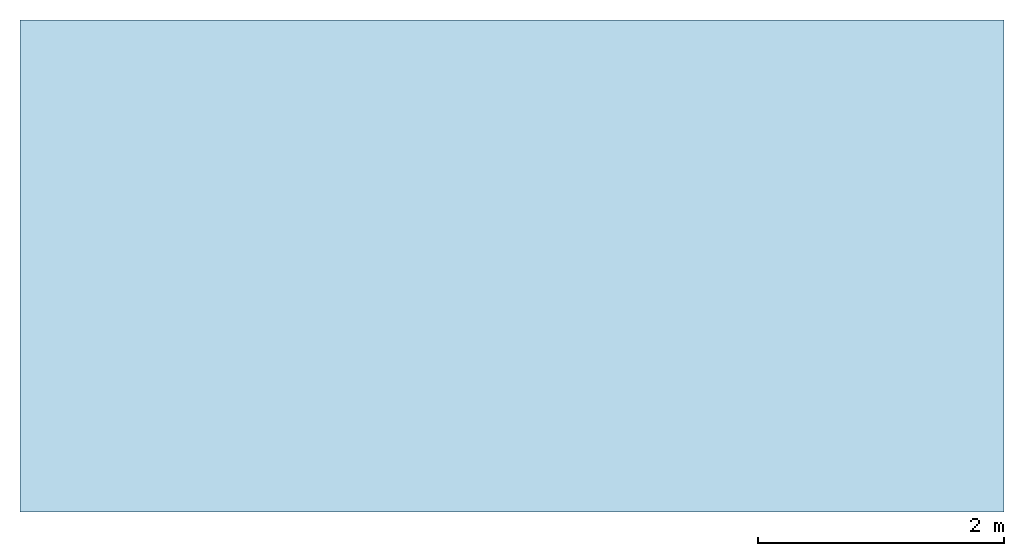
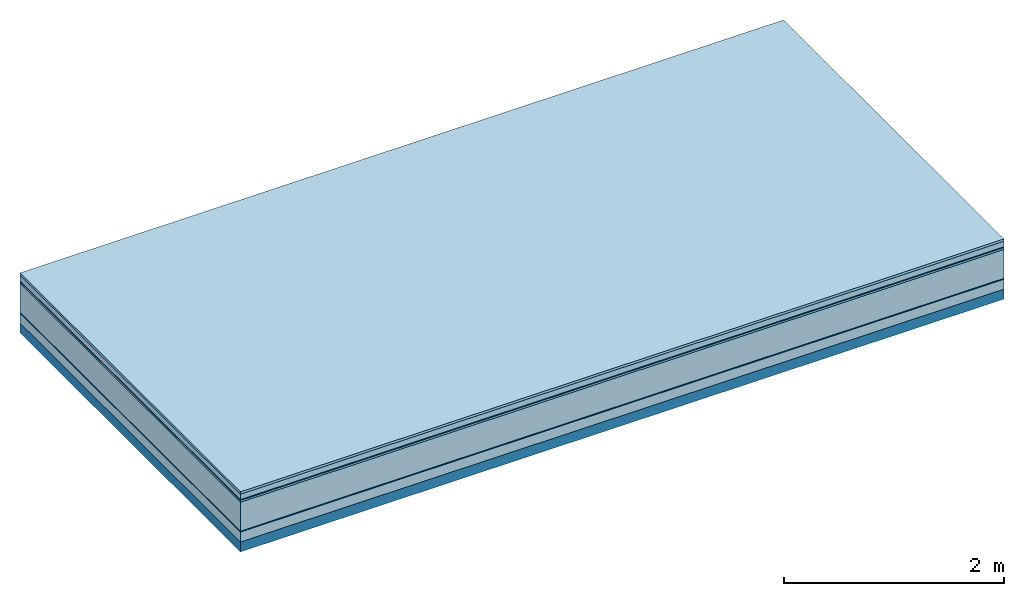
# One storey: 7 plates, 1 member, 1 element without a shape of its own.
"""IFC4 building model written with IfcOpenShell, lengths in metres."""

from ifc_helpers import new_model, si_unit, derived_unit, direction, frame, frame_2d, origin, origin_with_axes, place, context, project, spatial, rectangle, extrude, material, layer, layer_set, type_object, element, aggregate, save


model = new_model("IFC4")

# Units and contexts
plan_context = context("Plan", 3, precision=1e-05, world=origin(), true_north=direction((0.0, 1.0)))
model_context = context("Model", 3, precision=1e-05, world=origin(), true_north=direction((0.0, 1.0)))
ifc_project = project(units=[si_unit("LENGTHUNIT", "METRE"), derived_unit("SOUNDPRESSUREUNIT", [(si_unit("PRESSUREUNIT", "PASCAL", prefix="MICRO"), 0)]), si_unit("ENERGYUNIT", "JOULE", prefix="MEGA"), si_unit("MASSUNIT", "GRAM", prefix="KILO"), derived_unit("THERMALTRANSMITTANCEUNIT", [(si_unit("POWERUNIT", "WATT"), 1), (si_unit("AREAUNIT", "SQUARE_METRE"), -1), (si_unit("THERMODYNAMICTEMPERATUREUNIT", "KELVIN"), -1)]), derived_unit("AREADENSITYUNIT", [(si_unit("MASSUNIT", "GRAM", prefix="KILO"), 1), (si_unit("AREAUNIT", "SQUARE_METRE"), -1)]), derived_unit("USERDEFINED", [(si_unit("ENERGYUNIT", "JOULE", prefix="MEGA"), 1), (si_unit("AREAUNIT", "SQUARE_METRE"), -1)])], contexts=[plan_context, model_context])

# Site, building, storey
site = spatial("IfcSite", under=ifc_project)
building_placement = place(None, origin())
building = spatial("IfcBuilding", under=site, at=building_placement)
storey_placement = place(building_placement, origin())
storey = spatial("IfcBuildingStorey", under=building, at=storey_placement)

# Slab, member, plates
ifc_material_1 = material(Category="07.009")
ifc_layer_1 = layer(ifc_material_1, 0.026, Name="Use and protection layer 3")
ifc_material_2 = material(Category="07.011")
ifc_layer_2 = layer(ifc_material_2, 0.06, Name="Use and protection layer 2")
ifc_material_3 = material(Name="Protective layer + Fire protection cover RF1", Category="09.007")
ifc_layer_3 = layer(ifc_material_3, 0.01, Name="Use and protection layer 1")
ifc_material_4 = material(Name="Bituminous", Category="09.003")
ifc_layer_4 = layer(ifc_material_4, 0.02, Name="Seal")
ifc_material_5 = material(Name="Mineral wool", Category="10.008")
ifc_layer_5 = layer(ifc_material_5, 0.32, Name="Exterior insulation layer 1")
ifc_material_6 = material(Name="Vapor-permeable barrier", Category="09.006")
ifc_layer_6 = layer(ifc_material_6, 0.01, Name="layer / temporary roof")
ifc_material_7 = material(Category="01.002")
ifc_layer_7 = layer(ifc_material_7, 0.11, Name="above 1st layer")
ifc_material_8 = material(Name="Rigid, of the art")
ifc_layer_8 = layer(ifc_material_8, 0.0, Name="Bond")
ifc_layer_9 = layer(None, 0.11, Name="Support")
ifc_layer_set = layer_set([ifc_layer_1, ifc_layer_2, ifc_layer_3, ifc_layer_4, ifc_layer_5, ifc_layer_6, ifc_layer_7, ifc_layer_8, ifc_layer_9])
slab_type = type_object("IfcSlabType", Name="F0081", PredefinedType="NOTDEFINED", material=ifc_layer_set)
slab_placement = place(None, frame((0.0, 0.0, 0.0), z_axis=(0.0, 0.0, -1.0), x_axis=(1.0, 0.0, 0.0)))
slab = element("IfcSlab", 1, at=slab_placement, inside=storey, type_object=slab_type, material=ifc_layer_set, Name="Slab #1")
ifc_material_9 = material(Name="Solid timber panel")
member_placement = place(slab_placement, origin())
member = element("IfcMember", 2, at=member_placement, material=ifc_material_9, Name="Support", context=plan_context, shape_type="SweptSolid", body=[
    extrude(rectangle(XDim=1.0, YDim=0.11, at=frame_2d((0.5, 0.055), x_axis=(1.0, 0.0))), frame((0.0, 4.0, 0.556), z_axis=(0.0, -1.0, 0.0), x_axis=(1.0, 0.0, 0.0)), (0.0, 0.0, 1.0), 4.0),
    extrude(rectangle(XDim=1.0, YDim=0.11, at=frame_2d((0.5, 0.055), x_axis=(1.0, 0.0))), frame((1.0, 4.0, 0.556), z_axis=(0.0, -1.0, 0.0), x_axis=(1.0, 0.0, 0.0)), (0.0, 0.0, 1.0), 4.0),
    extrude(rectangle(XDim=1.0, YDim=0.11, at=frame_2d((0.5, 0.055), x_axis=(1.0, 0.0))), frame((2.0, 4.0, 0.556), z_axis=(0.0, -1.0, 0.0), x_axis=(1.0, 0.0, 0.0)), (0.0, 0.0, 1.0), 4.0),
    extrude(rectangle(XDim=1.0, YDim=0.11, at=frame_2d((0.5, 0.055), x_axis=(1.0, 0.0))), frame((3.0, 4.0, 0.556), z_axis=(0.0, -1.0, 0.0), x_axis=(1.0, 0.0, 0.0)), (0.0, 0.0, 1.0), 4.0),
    extrude(rectangle(XDim=1.0, YDim=0.11, at=frame_2d((0.5, 0.055), x_axis=(1.0, 0.0))), frame((4.0, 4.0, 0.556), z_axis=(0.0, -1.0, 0.0), x_axis=(1.0, 0.0, 0.0)), (0.0, 0.0, 1.0), 4.0),
    extrude(rectangle(XDim=1.0, YDim=0.11, at=frame_2d((0.5, 0.055), x_axis=(1.0, 0.0))), frame((5.0, 4.0, 0.556), z_axis=(0.0, -1.0, 0.0), x_axis=(1.0, 0.0, 0.0)), (0.0, 0.0, 1.0), 4.0),
    extrude(rectangle(XDim=1.0, YDim=0.11, at=frame_2d((0.5, 0.055), x_axis=(1.0, 0.0))), frame((6.0, 4.0, 0.556), z_axis=(0.0, -1.0, 0.0), x_axis=(1.0, 0.0, 0.0)), (0.0, 0.0, 1.0), 4.0),
    extrude(rectangle(XDim=1.0, YDim=0.11, at=frame_2d((0.5, 0.055), x_axis=(1.0, 0.0))), frame((7.0, 4.0, 0.556), z_axis=(0.0, -1.0, 0.0), x_axis=(1.0, 0.0, 0.0)), (0.0, 0.0, 1.0), 4.0),
])
plate_1_placement = place(slab_placement, origin())
plate_1 = element("IfcPlate", 3, at=plate_1_placement, material=ifc_material_1, Name="Use and protection layer 3", context=plan_context, shape_type="SweptSolid", body=[
    extrude(rectangle(XDim=8.0, YDim=4.0, at=frame_2d((4.0, 2.0), x_axis=(1.0, 0.0))), origin_with_axes(), (0.0, 0.0, 1.0), 0.026),
])
plate_2_placement = place(slab_placement, origin())
plate_2 = element("IfcPlate", 4, at=plate_2_placement, material=ifc_material_2, Name="Use and protection layer 2", context=plan_context, shape_type="SweptSolid", body=[
    extrude(rectangle(XDim=8.0, YDim=4.0, at=frame_2d((4.0, 2.0), x_axis=(1.0, 0.0))), frame((0.0, 0.0, 0.026), z_axis=(0.0, 0.0, 1.0), x_axis=(1.0, 0.0, 0.0)), (0.0, 0.0, 1.0), 0.06),
])
plate_3_placement = place(slab_placement, origin())
plate_3 = element("IfcPlate", 5, at=plate_3_placement, material=ifc_material_3, Name="Use and protection layer 1", context=plan_context, shape_type="SweptSolid", body=[
    extrude(rectangle(XDim=8.0, YDim=4.0, at=frame_2d((4.0, 2.0), x_axis=(1.0, 0.0))), frame((0.0, 0.0, 0.086), z_axis=(0.0, 0.0, 1.0), x_axis=(1.0, 0.0, 0.0)), (0.0, 0.0, 1.0), 0.01),
])
plate_4_placement = place(slab_placement, origin())
plate_4 = element("IfcPlate", 6, at=plate_4_placement, material=ifc_material_4, Name="Seal", context=plan_context, shape_type="SweptSolid", body=[
    extrude(rectangle(XDim=8.0, YDim=4.0, at=frame_2d((4.0, 2.0), x_axis=(1.0, 0.0))), frame((0.0, 0.0, 0.096), z_axis=(0.0, 0.0, 1.0), x_axis=(1.0, 0.0, 0.0)), (0.0, 0.0, 1.0), 0.02),
])
plate_5_placement = place(slab_placement, origin())
plate_5 = element("IfcPlate", 7, at=plate_5_placement, material=ifc_material_5, Name="Exterior insulation layer 1", context=plan_context, shape_type="SweptSolid", body=[
    extrude(rectangle(XDim=8.0, YDim=4.0, at=frame_2d((4.0, 2.0), x_axis=(1.0, 0.0))), frame((0.0, 0.0, 0.116), z_axis=(0.0, 0.0, 1.0), x_axis=(1.0, 0.0, 0.0)), (0.0, 0.0, 1.0), 0.32),
])
plate_6_placement = place(slab_placement, origin())
plate_6 = element("IfcPlate", 8, at=plate_6_placement, material=ifc_material_6, Name="layer / temporary roof", context=plan_context, shape_type="SweptSolid", body=[
    extrude(rectangle(XDim=8.0, YDim=4.0, at=frame_2d((4.0, 2.0), x_axis=(1.0, 0.0))), frame((0.0, 0.0, 0.436), z_axis=(0.0, 0.0, 1.0), x_axis=(1.0, 0.0, 0.0)), (0.0, 0.0, 1.0), 0.01),
])
plate_7_placement = place(slab_placement, origin())
plate_7 = element("IfcPlate", 9, at=plate_7_placement, material=ifc_material_7, Name="above 1st layer", context=plan_context, shape_type="SweptSolid", body=[
    extrude(rectangle(XDim=8.0, YDim=4.0, at=frame_2d((4.0, 2.0), x_axis=(1.0, 0.0))), frame((0.0, 0.0, 0.446), z_axis=(0.0, 0.0, 1.0), x_axis=(1.0, 0.0, 0.0)), (0.0, 0.0, 1.0), 0.11),
])
aggregate(slab, [plate_1, plate_2, plate_3, plate_4, plate_5, plate_6, plate_7, member])

save(model, "model.ifc")
